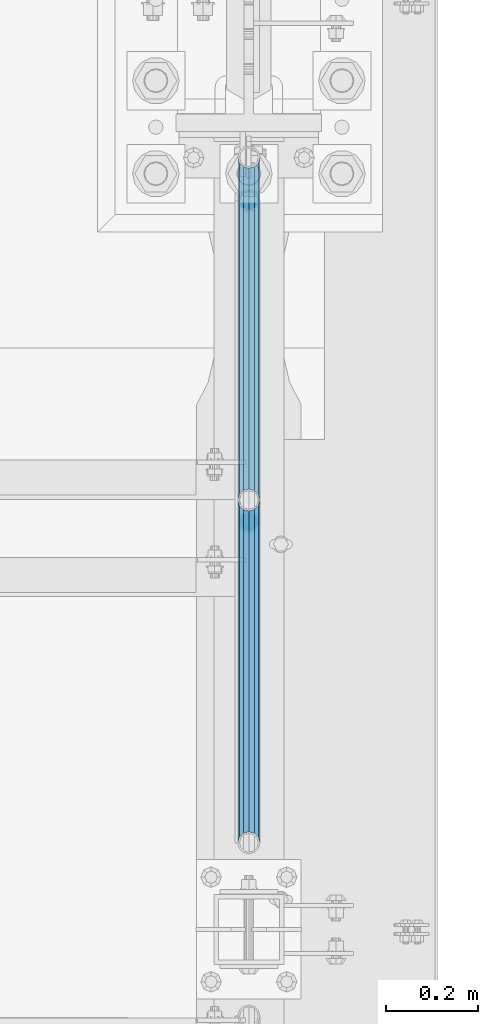
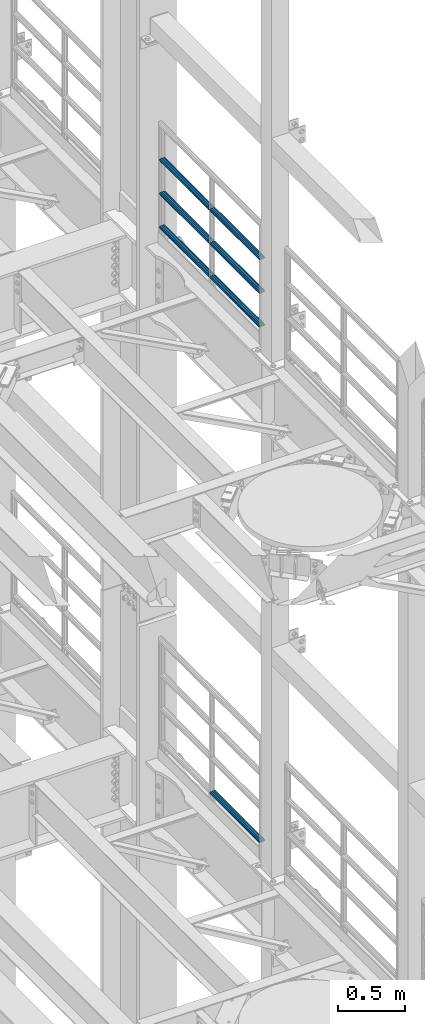
# One storey, part 1334 of 1876: 7 beams, 2 elements without a shape of their own.
"""IFC2X3 building model written with IfcOpenShell, lengths in millimetres."""

from ifc_helpers import new_model, si_unit, frame, origin_with_axes, place, context, subcontext, project, spatial, faceted_brep, material, type_object, element, aggregate, save


model = new_model("IFC2X3")

# Units and contexts
model_context = context("Model", 3, precision=1e-05, world=origin_with_axes())
body_context = subcontext(model_context, "Body", "Model", "MODEL_VIEW")
ifc_project = project(units=[si_unit("LENGTHUNIT", "METRE", prefix="MILLI"), si_unit("AREAUNIT", "SQUARE_METRE"), si_unit("VOLUMEUNIT", "CUBIC_METRE"), si_unit("MASSUNIT", "GRAM", prefix="KILO"), si_unit("TIMEUNIT", "SECOND"), si_unit("PLANEANGLEUNIT", "RADIAN"), si_unit("SOLIDANGLEUNIT", "STERADIAN"), si_unit("THERMODYNAMICTEMPERATUREUNIT", "DEGREE_CELSIUS"), si_unit("LUMINOUSINTENSITYUNIT", "LUMEN")], contexts=[model_context])

# Site, building, storey
site_placement = place(None, origin_with_axes())
site = spatial("IfcSite", under=ifc_project, at=site_placement, CompositionType="ELEMENT")
building_placement = place(site_placement, origin_with_axes())
building = spatial("IfcBuilding", under=site, at=building_placement, Name="Undefined", CompositionType="ELEMENT")
storey_placement = place(building_placement, origin_with_axes())
storey = spatial("IfcBuildingStorey", under=building, at=storey_placement, Name="Undefined", CompositionType="ELEMENT", Elevation=0.0)

# Assembly, beams
assembly_1_placement = place(storey_placement, origin_with_axes())
assembly_1 = element("IfcElementAssembly", 1, at=assembly_1_placement, inside=storey, Name="RAIL", AssemblyPlace="NOTDEFINED", PredefinedType="RIGID_FRAME")
ifc_material = material()
beam_type = type_object("IfcBeamType", Name="PIPE1-1/2SCH40", PredefinedType="NOTDEFINED")
beam_1_placement = place(assembly_1_placement, frame((7620.0, 6526.2125, 18145.125), z_axis=(0.0, 0.0, 1.0), x_axis=(0.0, -1.0, 0.0)))
beam_1 = element("IfcBeam", 2, at=beam_1_placement, type_object=beam_type, material=ifc_material, Name="RAIL", ObjectType="PIPE1-1/2SCH40", context=body_context, shape_type="Brep", body=[
    faceted_brep([(728.085307006683, -12.0649999999996, 20.8971929933177), (728.085307006683, -12.0649999999996, 15.8661214311796), (727.591878568821, -10.2235000000001, 17.7076214311819), (724.852500000002, 0.0, 20.4470000000001), (724.852500000002, 0.0, 24.130000000001), (727.591878568821, 10.2235000000001, 17.7076214311819), (728.085307006683, 12.0649999999996, 15.8661214311796), (728.085307006683, 12.0649999999996, 20.8971929933177), (748.982500000002, 24.1300000000001, 0.0), (736.917500000002, 20.8971929933186, 12.0649999999987), (736.917500000002, 20.8971929933186, -12.0649999999987), (733.727928437864, 17.7076214311801, 10.2235000000001), (736.467307006683, 20.4470000000001, 0.0), (733.727928437864, 17.7076214311801, -10.2235000000001), (728.085307006683, 12.0649999999996, -15.8661214311796), (728.085307006683, 12.0649999999996, -20.8971929933177), (727.591878568821, 10.2235000000001, -17.7076214311819), (724.852500000002, 0.0, -20.4470000000001), (724.852500000002, 0.0, -24.130000000001), (728.085307006683, -12.0649999999996, -15.8661214311796), (728.085307006683, -12.0649999999996, -20.8971929933177), (727.591878568821, -10.2235000000001, -17.7076214311819), (748.982500000002, -24.1300000000001, 0.0), (736.917500000002, -20.8971929933186, -12.0649999999987), (736.917500000002, -20.8971929933186, 12.0649999999987), (733.727928437864, -17.7076214311801, -10.2235000000001), (736.467307006683, -20.4470000000001, 0.0), (733.727928437864, -17.7076214311801, 10.2235000000001), (12.0650000000064, -20.8971929933177, -12.0649999999987), (20.8971929933249, -12.0650000000005, -20.8971929933177), (0.0, 24.1299999999992, 0.0), (12.0650000000064, 20.8971929933177, -12.0649999999987), (12.0650000000064, 20.8971929933177, 12.0649999999987), (20.8971929933249, 12.0650000000005, 20.8971929933177), (24.1300000000064, 0.0, 24.130000000001), (20.8971929933249, 12.0650000000005, -20.8971929933177), (24.1300000000063, 0.0, -24.130000000001), (24.1300000000063, 0.0, -20.4470000000001), (20.8971929933249, -12.0650000000005, -15.8661214311796), (21.3906214311868, -10.2235000000001, -17.7076214311819), (21.3906214311868, 10.2235000000001, -17.7076214311819), (20.8971929933249, 12.0650000000005, -15.8661214311796), (15.2545715621445, 17.7076214311801, -10.2235000000001), (12.5151929933249, 20.4470000000001, 0.0), (15.2545715621445, 17.7076214311801, 10.2235000000001), (20.8971929933249, 12.0650000000005, 15.8661214311796), (21.3906214311868, 10.2235000000001, 17.7076214311819), (24.1300000000064, 0.0, 20.4470000000001), (21.3906214311868, -10.2235000000001, 17.7076214311819), (20.8971929933249, -12.0650000000005, 15.8661214311796), (20.8971929933249, -12.0650000000005, 20.8971929933177), (12.0650000000064, -20.8971929933177, 12.0649999999987), (0.0, -24.1299999999992, 0.0), (15.2545715621445, -17.7076214311801, 10.2235000000001), (12.5151929933249, -20.4470000000001, 0.0), (15.2545715621445, -17.7076214311801, -10.2235000000001)], [[[0, 1, 2, 3, 4]], [[4, 3, 5, 6, 7]], [[8, 9, 10]], [[7, 6, 11, 12, 13, 14, 15, 10, 9]], [[16, 17, 18, 15, 14]], [[19, 20, 18, 17, 21]], [[22, 23, 24]], [[24, 23, 20, 19, 25, 26, 27, 1, 0]], [[28, 29, 20, 23]], [[30, 31, 32]], [[33, 34, 4, 7]], [[32, 33, 7, 9]], [[30, 32, 9, 8]], [[31, 30, 8, 10]], [[35, 31, 10, 15]], [[36, 35, 15, 18]], [[29, 36, 18, 20]], [[37, 36, 29, 38, 39]], [[40, 41, 35, 36, 37]], [[32, 31, 35, 41, 42, 43, 44, 45, 33]], [[33, 45, 46, 47, 34]], [[34, 47, 48, 49, 50]], [[34, 50, 0, 4]], [[50, 51, 24, 0]], [[51, 52, 22, 24]], [[52, 28, 23, 22]], [[51, 28, 52]], [[50, 49, 53, 54, 55, 38, 29, 28, 51]], [[55, 54, 26, 25]], [[21, 39, 38, 55, 25, 19]], [[37, 39, 21, 17]], [[40, 37, 17, 16]], [[42, 41, 40, 16, 14, 13]], [[43, 42, 13, 12]], [[44, 43, 12, 11]], [[5, 46, 45, 44, 11, 6]], [[47, 46, 5, 3]], [[48, 47, 3, 2]], [[53, 49, 48, 2, 1, 27]], [[54, 53, 27, 26]]]),
])
beam_2_placement = place(assembly_1_placement, frame((7619.99999999999, 7275.195, 18145.125), z_axis=(0.0, 0.0, 1.0), x_axis=(0.0, -1.0, 0.0)))
beam_2 = element("IfcBeam", 3, at=beam_2_placement, type_object=beam_type, material=ifc_material, Name="RAIL", ObjectType="PIPE1-1/2SCH40", context=body_context, shape_type="Brep", body=[
    faceted_brep([(728.085307006683, -12.0649999999996, 20.8971929933177), (728.085307006683, -12.0649999999996, 15.8661214311796), (727.591878568821, -10.2235000000001, 17.7076214311819), (724.852500000002, 0.0, 20.4470000000001), (724.852500000002, 0.0, 24.130000000001), (727.591878568821, 10.2235000000001, 17.7076214311819), (728.085307006683, 12.0649999999996, 15.8661214311796), (728.085307006683, 12.0649999999996, 20.8971929933177), (748.982500000002, 24.1300000000001, 0.0), (736.917500000002, 20.8971929933186, 12.0649999999987), (736.917500000002, 20.8971929933186, -12.0649999999987), (733.727928437864, 17.7076214311801, 10.2235000000001), (736.467307006683, 20.4470000000001, 0.0), (733.727928437864, 17.7076214311801, -10.2235000000001), (728.085307006683, 12.0649999999996, -15.8661214311796), (728.085307006683, 12.0649999999996, -20.8971929933177), (727.591878568821, 10.2235000000001, -17.7076214311819), (724.852500000002, 0.0, -20.4470000000001), (724.852500000002, 0.0, -24.130000000001), (728.085307006683, -12.0649999999996, -15.8661214311796), (728.085307006683, -12.0649999999996, -20.8971929933177), (727.591878568821, -10.2235000000001, -17.7076214311819), (748.982500000002, -24.1300000000001, 0.0), (736.917500000002, -20.8971929933186, -12.0649999999987), (736.917500000002, -20.8971929933186, 12.0649999999987), (733.727928437864, -17.7076214311801, -10.2235000000001), (736.467307006683, -20.4470000000001, 0.0), (733.727928437864, -17.7076214311801, 10.2235000000001), (12.0650000000064, -20.8971929933177, -12.0649999999987), (20.8971929933249, -12.0650000000005, -20.8971929933177), (0.0, 24.1299999999992, 0.0), (12.0650000000064, 20.8971929933177, -12.0649999999987), (12.0650000000064, 20.8971929933177, 12.0649999999987), (20.8971929933249, 12.0650000000005, 20.8971929933177), (24.1300000000064, 0.0, 24.130000000001), (20.8971929933249, 12.0650000000005, -20.8971929933177), (24.1300000000063, 0.0, -24.130000000001), (24.1300000000063, 0.0, -20.4470000000001), (20.8971929933249, -12.0650000000005, -15.8661214311796), (21.3906214311868, -10.2235000000001, -17.7076214311819), (21.3906214311868, 10.2235000000001, -17.7076214311819), (20.8971929933249, 12.0650000000005, -15.8661214311796), (15.2545715621445, 17.7076214311801, -10.2235000000001), (12.5151929933249, 20.4470000000001, 0.0), (15.2545715621445, 17.7076214311801, 10.2235000000001), (20.8971929933249, 12.0650000000005, 15.8661214311796), (21.3906214311868, 10.2235000000001, 17.7076214311819), (24.1300000000064, 0.0, 20.4470000000001), (21.3906214311868, -10.2235000000001, 17.7076214311819), (20.8971929933249, -12.0650000000005, 15.8661214311796), (20.8971929933249, -12.0650000000005, 20.8971929933177), (12.0650000000064, -20.8971929933177, 12.0649999999987), (0.0, -24.1299999999992, 0.0), (15.2545715621445, -17.7076214311801, 10.2235000000001), (12.5151929933249, -20.4470000000001, 0.0), (15.2545715621445, -17.7076214311801, -10.2235000000001)], [[[0, 1, 2, 3, 4]], [[4, 3, 5, 6, 7]], [[8, 9, 10]], [[7, 6, 11, 12, 13, 14, 15, 10, 9]], [[16, 17, 18, 15, 14]], [[19, 20, 18, 17, 21]], [[22, 23, 24]], [[24, 23, 20, 19, 25, 26, 27, 1, 0]], [[28, 29, 20, 23]], [[30, 31, 32]], [[33, 34, 4, 7]], [[32, 33, 7, 9]], [[30, 32, 9, 8]], [[31, 30, 8, 10]], [[35, 31, 10, 15]], [[36, 35, 15, 18]], [[29, 36, 18, 20]], [[37, 36, 29, 38, 39]], [[40, 41, 35, 36, 37]], [[32, 31, 35, 41, 42, 43, 44, 45, 33]], [[33, 45, 46, 47, 34]], [[34, 47, 48, 49, 50]], [[34, 50, 0, 4]], [[50, 51, 24, 0]], [[51, 52, 22, 24]], [[52, 28, 23, 22]], [[51, 28, 52]], [[50, 49, 53, 54, 55, 38, 29, 28, 51]], [[55, 54, 26, 25]], [[21, 39, 38, 55, 25, 19]], [[37, 39, 21, 17]], [[40, 37, 17, 16]], [[42, 41, 40, 16, 14, 13]], [[43, 42, 13, 12]], [[44, 43, 12, 11]], [[5, 46, 45, 44, 11, 6]], [[47, 46, 5, 3]], [[48, 47, 3, 2]], [[53, 49, 48, 2, 1, 27]], [[54, 53, 27, 26]]]),
])
beam_3_placement = place(assembly_1_placement, frame((7620.0, 5777.23, 18449.925), z_axis=(0.0, 0.0, -1.0), x_axis=(0.0, 1.0, 0.0)))
beam_3 = element("IfcBeam", 4, at=beam_3_placement, type_object=beam_type, material=ifc_material, Name="RAIL", ObjectType="PIPE1-1/2SCH40", context=body_context, shape_type="Brep", body=[
    faceted_brep([(0.0, 24.1299999999992, 0.0), (12.0650000000064, 20.8971929933177, -12.0649999999987), (12.0650000000064, 20.8971929933177, 12.0649999999987), (12.0650000000064, -20.8971929933177, 12.0649999999987), (12.0650000000064, -20.8971929933177, -12.0649999999987), (0.0, -24.1299999999992, 0.0), (20.8971929933249, -12.0650000000005, 20.8971929933177), (20.8971929933249, -12.0650000000005, 15.8661214311796), (15.2545715621445, -17.7076214311801, 10.2235000000001), (12.5151929933249, -20.4470000000001, 0.0), (15.2545715621445, -17.7076214311801, -10.2235000000001), (20.8971929933249, -12.0650000000005, -15.8661214311796), (20.8971929933249, -12.0650000000005, -20.8971929933177), (24.1300000000063, 0.0, -20.4470000000001), (24.1300000000063, 0.0, -24.130000000001), (21.3906214311868, -10.2235000000001, -17.7076214311819), (21.3906214311868, 10.2235000000001, -17.7076214311819), (20.8971929933249, 12.0650000000005, -15.8661214311796), (20.8971929933249, 12.0650000000005, -20.8971929933177), (15.2545715621445, 17.7076214311801, -10.2235000000001), (12.5151929933249, 20.4470000000001, 0.0), (15.2545715621445, 17.7076214311801, 10.2235000000001), (20.8971929933249, 12.0650000000005, 15.8661214311796), (20.8971929933249, 12.0650000000005, 20.8971929933177), (21.3906214311868, 10.2235000000001, 17.7076214311819), (24.1300000000064, 0.0, 20.4470000000001), (24.1300000000064, 0.0, 24.130000000001), (21.3906214311868, -10.2235000000001, 17.7076214311819), (748.982500000002, 24.1300000000001, 0.0), (736.917500000002, 20.8971929933186, -12.0649999999987), (728.085307006683, 12.0649999999996, -20.8971929933177), (748.982500000002, -24.1300000000001, 0.0), (736.917500000002, -20.8971929933186, -12.0649999999987), (736.917500000002, -20.8971929933186, 12.0649999999987), (728.085307006683, -12.0649999999996, 20.8971929933177), (728.085307006683, -12.0649999999996, -20.8971929933177), (724.852500000002, 0.0, -24.130000000001), (727.591878568821, 10.2235000000001, -17.7076214311819), (724.852500000002, 0.0, -20.4470000000001), (728.085307006683, 12.0649999999996, -15.8661214311796), (728.085307006683, -12.0649999999996, -15.8661214311796), (727.591878568821, -10.2235000000001, -17.7076214311819), (733.727928437864, -17.7076214311801, -10.2235000000001), (736.467307006683, -20.4470000000001, 0.0), (733.727928437864, -17.7076214311801, 10.2235000000001), (728.085307006683, -12.0649999999996, 15.8661214311796), (727.591878568821, -10.2235000000001, 17.7076214311819), (724.852500000002, 0.0, 20.4470000000001), (724.852500000002, 0.0, 24.130000000001), (728.085307006683, 12.0649999999996, 20.8971929933177), (736.917500000002, 20.8971929933186, 12.0649999999987), (728.085307006683, 12.0649999999996, 15.8661214311796), (733.727928437864, 17.7076214311801, 10.2235000000001), (736.467307006683, 20.4470000000001, 0.0), (733.727928437864, 17.7076214311801, -10.2235000000001), (727.591878568821, 10.2235000000001, 17.7076214311819)], [[[0, 1, 2]], [[3, 4, 5]], [[6, 7, 8, 9, 10, 11, 12, 4, 3]], [[13, 14, 12, 11, 15]], [[16, 17, 18, 14, 13]], [[2, 1, 18, 17, 19, 20, 21, 22, 23]], [[23, 22, 24, 25, 26]], [[26, 25, 27, 7, 6]], [[1, 0, 28, 29]], [[18, 1, 29, 30]], [[31, 32, 33]], [[6, 3, 33, 34]], [[3, 5, 31, 33]], [[5, 4, 32, 31]], [[4, 12, 35, 32]], [[12, 14, 36, 35]], [[14, 18, 30, 36]], [[37, 38, 36, 30, 39]], [[40, 35, 36, 38, 41]], [[33, 32, 35, 40, 42, 43, 44, 45, 34]], [[34, 45, 46, 47, 48]], [[26, 6, 34, 48]], [[2, 23, 49, 50]], [[23, 26, 48, 49]], [[0, 2, 50, 28]], [[28, 50, 29]], [[49, 51, 52, 53, 54, 39, 30, 29, 50]], [[48, 47, 55, 51, 49]], [[25, 24, 55, 47]], [[55, 24, 22, 21, 52, 51]], [[21, 20, 53, 52]], [[20, 19, 54, 53]], [[19, 17, 16, 37, 39, 54]], [[16, 13, 38, 37]], [[13, 15, 41, 38]], [[41, 15, 11, 10, 42, 40]], [[10, 9, 43, 42]], [[9, 8, 44, 43]], [[8, 7, 27, 46, 45, 44]], [[27, 25, 47, 46]]]),
])
beam_4_placement = place(assembly_1_placement, frame((7620.0, 6526.2125, 18449.925), z_axis=(0.0, 0.0, -1.0), x_axis=(0.0, 1.0, 0.0)))
beam_4 = element("IfcBeam", 5, at=beam_4_placement, type_object=beam_type, material=ifc_material, Name="RAIL", ObjectType="PIPE1-1/2SCH40", context=body_context, shape_type="Brep", body=[
    faceted_brep([(0.0, 24.1299999999992, 0.0), (12.0650000000064, 20.8971929933177, -12.0649999999987), (12.0650000000064, 20.8971929933177, 12.0649999999987), (12.0650000000064, -20.8971929933177, 12.0649999999987), (12.0650000000064, -20.8971929933177, -12.0649999999987), (0.0, -24.1299999999992, 0.0), (20.8971929933249, -12.0650000000005, 20.8971929933177), (20.8971929933249, -12.0650000000005, 15.8661214311796), (15.2545715621445, -17.7076214311801, 10.2235000000001), (12.5151929933249, -20.4470000000001, 0.0), (15.2545715621445, -17.7076214311801, -10.2235000000001), (20.8971929933249, -12.0650000000005, -15.8661214311796), (20.8971929933249, -12.0650000000005, -20.8971929933177), (24.1300000000063, 0.0, -20.4470000000001), (24.1300000000063, 0.0, -24.130000000001), (21.3906214311868, -10.2235000000001, -17.7076214311819), (21.3906214311868, 10.2235000000001, -17.7076214311819), (20.8971929933249, 12.0650000000005, -15.8661214311796), (20.8971929933249, 12.0650000000005, -20.8971929933177), (15.2545715621445, 17.7076214311801, -10.2235000000001), (12.5151929933249, 20.4470000000001, 0.0), (15.2545715621445, 17.7076214311801, 10.2235000000001), (20.8971929933249, 12.0650000000005, 15.8661214311796), (20.8971929933249, 12.0650000000005, 20.8971929933177), (21.3906214311868, 10.2235000000001, 17.7076214311819), (24.1300000000064, 0.0, 20.4470000000001), (24.1300000000064, 0.0, 24.130000000001), (21.3906214311868, -10.2235000000001, 17.7076214311819), (748.982500000002, 24.1300000000001, 0.0), (736.917500000002, 20.8971929933186, -12.0649999999987), (728.085307006683, 12.0649999999996, -20.8971929933177), (748.982500000002, -24.1300000000001, 0.0), (736.917500000002, -20.8971929933186, -12.0649999999987), (736.917500000002, -20.8971929933186, 12.0649999999987), (728.085307006683, -12.0649999999996, 20.8971929933177), (728.085307006683, -12.0649999999996, -20.8971929933177), (724.852500000002, 0.0, -24.130000000001), (727.591878568821, 10.2235000000001, -17.7076214311819), (724.852500000002, 0.0, -20.4470000000001), (728.085307006683, 12.0649999999996, -15.8661214311796), (728.085307006683, -12.0649999999996, -15.8661214311796), (727.591878568821, -10.2235000000001, -17.7076214311819), (733.727928437864, -17.7076214311801, -10.2235000000001), (736.467307006683, -20.4470000000001, 0.0), (733.727928437864, -17.7076214311801, 10.2235000000001), (728.085307006683, -12.0649999999996, 15.8661214311796), (727.591878568821, -10.2235000000001, 17.7076214311819), (724.852500000002, 0.0, 20.4470000000001), (724.852500000002, 0.0, 24.130000000001), (728.085307006683, 12.0649999999996, 20.8971929933177), (736.917500000002, 20.8971929933186, 12.0649999999987), (728.085307006683, 12.0649999999996, 15.8661214311796), (733.727928437864, 17.7076214311801, 10.2235000000001), (736.467307006683, 20.4470000000001, 0.0), (733.727928437864, 17.7076214311801, -10.2235000000001), (727.591878568821, 10.2235000000001, 17.7076214311819)], [[[0, 1, 2]], [[3, 4, 5]], [[6, 7, 8, 9, 10, 11, 12, 4, 3]], [[13, 14, 12, 11, 15]], [[16, 17, 18, 14, 13]], [[2, 1, 18, 17, 19, 20, 21, 22, 23]], [[23, 22, 24, 25, 26]], [[26, 25, 27, 7, 6]], [[1, 0, 28, 29]], [[18, 1, 29, 30]], [[31, 32, 33]], [[6, 3, 33, 34]], [[3, 5, 31, 33]], [[5, 4, 32, 31]], [[4, 12, 35, 32]], [[12, 14, 36, 35]], [[14, 18, 30, 36]], [[37, 38, 36, 30, 39]], [[40, 35, 36, 38, 41]], [[33, 32, 35, 40, 42, 43, 44, 45, 34]], [[34, 45, 46, 47, 48]], [[26, 6, 34, 48]], [[2, 23, 49, 50]], [[23, 26, 48, 49]], [[0, 2, 50, 28]], [[28, 50, 29]], [[49, 51, 52, 53, 54, 39, 30, 29, 50]], [[48, 47, 55, 51, 49]], [[25, 24, 55, 47]], [[55, 24, 22, 21, 52, 51]], [[21, 20, 53, 52]], [[20, 19, 54, 53]], [[19, 17, 16, 37, 39, 54]], [[16, 13, 38, 37]], [[13, 15, 41, 38]], [[41, 15, 11, 10, 42, 40]], [[10, 9, 43, 42]], [[9, 8, 44, 43]], [[8, 7, 27, 46, 45, 44]], [[27, 25, 47, 46]]]),
])
beam_5_placement = place(assembly_1_placement, frame((7620.0, 5777.23, 18754.725), z_axis=(0.0, 0.0, -1.0), x_axis=(0.0, 1.0, 0.0)))
beam_5 = element("IfcBeam", 6, at=beam_5_placement, type_object=beam_type, material=ifc_material, Name="RAIL", ObjectType="PIPE1-1/2SCH40", context=body_context, shape_type="Brep", body=[
    faceted_brep([(0.0, 24.1299999999992, 0.0), (12.0650000000064, 20.8971929933177, -12.0649999999987), (12.0650000000064, 20.8971929933177, 12.0649999999987), (12.0650000000064, -20.8971929933177, 12.0649999999987), (12.0650000000064, -20.8971929933177, -12.0649999999987), (0.0, -24.1299999999992, 0.0), (20.8971929933249, -12.0650000000005, 20.8971929933177), (20.8971929933249, -12.0650000000005, 15.8661214311796), (15.2545715621445, -17.7076214311801, 10.2235000000001), (12.5151929933249, -20.4470000000001, 0.0), (15.2545715621445, -17.7076214311801, -10.2235000000001), (20.8971929933249, -12.0650000000005, -15.8661214311796), (20.8971929933249, -12.0650000000005, -20.8971929933177), (24.1300000000063, 0.0, -20.4470000000001), (24.1300000000063, 0.0, -24.130000000001), (21.3906214311868, -10.2235000000001, -17.7076214311819), (21.3906214311868, 10.2235000000001, -17.7076214311819), (20.8971929933249, 12.0650000000005, -15.8661214311796), (20.8971929933249, 12.0650000000005, -20.8971929933177), (15.2545715621445, 17.7076214311801, -10.2235000000001), (12.5151929933249, 20.4470000000001, 0.0), (15.2545715621445, 17.7076214311801, 10.2235000000001), (20.8971929933249, 12.0650000000005, 15.8661214311796), (20.8971929933249, 12.0650000000005, 20.8971929933177), (21.3906214311868, 10.2235000000001, 17.7076214311819), (24.1300000000064, 0.0, 20.4470000000001), (24.1300000000064, 0.0, 24.130000000001), (21.3906214311868, -10.2235000000001, 17.7076214311819), (748.982500000002, 24.1300000000001, 0.0), (736.917500000002, 20.8971929933186, -12.0649999999987), (728.085307006683, 12.0649999999996, -20.8971929933177), (748.982500000002, -24.1300000000001, 0.0), (736.917500000002, -20.8971929933186, -12.0649999999987), (736.917500000002, -20.8971929933186, 12.0649999999987), (728.085307006683, -12.0649999999996, 20.8971929933177), (728.085307006683, -12.0649999999996, -20.8971929933177), (724.852500000002, 0.0, -24.130000000001), (727.591878568821, 10.2235000000001, -17.7076214311819), (724.852500000002, 0.0, -20.4470000000001), (728.085307006683, 12.0649999999996, -15.8661214311796), (728.085307006683, -12.0649999999996, -15.8661214311796), (727.591878568821, -10.2235000000001, -17.7076214311819), (733.727928437864, -17.7076214311801, -10.2235000000001), (736.467307006683, -20.4470000000001, 0.0), (733.727928437864, -17.7076214311801, 10.2235000000001), (728.085307006683, -12.0649999999996, 15.8661214311796), (727.591878568821, -10.2235000000001, 17.7076214311819), (724.852500000002, 0.0, 20.4470000000001), (724.852500000002, 0.0, 24.130000000001), (728.085307006683, 12.0649999999996, 20.8971929933177), (736.917500000002, 20.8971929933186, 12.0649999999987), (728.085307006683, 12.0649999999996, 15.8661214311796), (733.727928437864, 17.7076214311801, 10.2235000000001), (736.467307006683, 20.4470000000001, 0.0), (733.727928437864, 17.7076214311801, -10.2235000000001), (727.591878568821, 10.2235000000001, 17.7076214311819)], [[[0, 1, 2]], [[3, 4, 5]], [[6, 7, 8, 9, 10, 11, 12, 4, 3]], [[13, 14, 12, 11, 15]], [[16, 17, 18, 14, 13]], [[2, 1, 18, 17, 19, 20, 21, 22, 23]], [[23, 22, 24, 25, 26]], [[26, 25, 27, 7, 6]], [[1, 0, 28, 29]], [[18, 1, 29, 30]], [[31, 32, 33]], [[6, 3, 33, 34]], [[3, 5, 31, 33]], [[5, 4, 32, 31]], [[4, 12, 35, 32]], [[12, 14, 36, 35]], [[14, 18, 30, 36]], [[37, 38, 36, 30, 39]], [[40, 35, 36, 38, 41]], [[33, 32, 35, 40, 42, 43, 44, 45, 34]], [[34, 45, 46, 47, 48]], [[26, 6, 34, 48]], [[2, 23, 49, 50]], [[23, 26, 48, 49]], [[0, 2, 50, 28]], [[28, 50, 29]], [[49, 51, 52, 53, 54, 39, 30, 29, 50]], [[48, 47, 55, 51, 49]], [[25, 24, 55, 47]], [[55, 24, 22, 21, 52, 51]], [[21, 20, 53, 52]], [[20, 19, 54, 53]], [[19, 17, 16, 37, 39, 54]], [[16, 13, 38, 37]], [[13, 15, 41, 38]], [[41, 15, 11, 10, 42, 40]], [[10, 9, 43, 42]], [[9, 8, 44, 43]], [[8, 7, 27, 46, 45, 44]], [[27, 25, 47, 46]]]),
])
beam_6_placement = place(assembly_1_placement, frame((7620.0, 6526.2125, 18754.725), z_axis=(0.0, 0.0, -1.0), x_axis=(0.0, 1.0, 0.0)))
beam_6 = element("IfcBeam", 7, at=beam_6_placement, type_object=beam_type, material=ifc_material, Name="RAIL", ObjectType="PIPE1-1/2SCH40", context=body_context, shape_type="Brep", body=[
    faceted_brep([(0.0, 24.1299999999992, 0.0), (12.0650000000064, 20.8971929933177, -12.0649999999987), (12.0650000000064, 20.8971929933177, 12.0649999999987), (12.0650000000064, -20.8971929933177, 12.0649999999987), (12.0650000000064, -20.8971929933177, -12.0649999999987), (0.0, -24.1299999999992, 0.0), (20.8971929933249, -12.0650000000005, 20.8971929933177), (20.8971929933249, -12.0650000000005, 15.8661214311796), (15.2545715621445, -17.7076214311801, 10.2235000000001), (12.5151929933249, -20.4470000000001, 0.0), (15.2545715621445, -17.7076214311801, -10.2235000000001), (20.8971929933249, -12.0650000000005, -15.8661214311796), (20.8971929933249, -12.0650000000005, -20.8971929933177), (24.1300000000063, 0.0, -20.4470000000001), (24.1300000000063, 0.0, -24.130000000001), (21.3906214311868, -10.2235000000001, -17.7076214311819), (21.3906214311868, 10.2235000000001, -17.7076214311819), (20.8971929933249, 12.0650000000005, -15.8661214311796), (20.8971929933249, 12.0650000000005, -20.8971929933177), (15.2545715621445, 17.7076214311801, -10.2235000000001), (12.5151929933249, 20.4470000000001, 0.0), (15.2545715621445, 17.7076214311801, 10.2235000000001), (20.8971929933249, 12.0650000000005, 15.8661214311796), (20.8971929933249, 12.0650000000005, 20.8971929933177), (21.3906214311868, 10.2235000000001, 17.7076214311819), (24.1300000000064, 0.0, 20.4470000000001), (24.1300000000064, 0.0, 24.130000000001), (21.3906214311868, -10.2235000000001, 17.7076214311819), (748.982500000002, 24.1300000000001, 0.0), (736.917500000002, 20.8971929933186, -12.0649999999987), (728.085307006683, 12.0649999999996, -20.8971929933177), (748.982500000002, -24.1300000000001, 0.0), (736.917500000002, -20.8971929933186, -12.0649999999987), (736.917500000002, -20.8971929933186, 12.0649999999987), (728.085307006683, -12.0649999999996, 20.8971929933177), (728.085307006683, -12.0649999999996, -20.8971929933177), (724.852500000002, 0.0, -24.130000000001), (727.591878568821, 10.2235000000001, -17.7076214311819), (724.852500000002, 0.0, -20.4470000000001), (728.085307006683, 12.0649999999996, -15.8661214311796), (728.085307006683, -12.0649999999996, -15.8661214311796), (727.591878568821, -10.2235000000001, -17.7076214311819), (733.727928437864, -17.7076214311801, -10.2235000000001), (736.467307006683, -20.4470000000001, 0.0), (733.727928437864, -17.7076214311801, 10.2235000000001), (728.085307006683, -12.0649999999996, 15.8661214311796), (727.591878568821, -10.2235000000001, 17.7076214311819), (724.852500000002, 0.0, 20.4470000000001), (724.852500000002, 0.0, 24.130000000001), (728.085307006683, 12.0649999999996, 20.8971929933177), (736.917500000002, 20.8971929933186, 12.0649999999987), (728.085307006683, 12.0649999999996, 15.8661214311796), (733.727928437864, 17.7076214311801, 10.2235000000001), (736.467307006683, 20.4470000000001, 0.0), (733.727928437864, 17.7076214311801, -10.2235000000001), (727.591878568821, 10.2235000000001, 17.7076214311819)], [[[0, 1, 2]], [[3, 4, 5]], [[6, 7, 8, 9, 10, 11, 12, 4, 3]], [[13, 14, 12, 11, 15]], [[16, 17, 18, 14, 13]], [[2, 1, 18, 17, 19, 20, 21, 22, 23]], [[23, 22, 24, 25, 26]], [[26, 25, 27, 7, 6]], [[1, 0, 28, 29]], [[18, 1, 29, 30]], [[31, 32, 33]], [[6, 3, 33, 34]], [[3, 5, 31, 33]], [[5, 4, 32, 31]], [[4, 12, 35, 32]], [[12, 14, 36, 35]], [[14, 18, 30, 36]], [[37, 38, 36, 30, 39]], [[40, 35, 36, 38, 41]], [[33, 32, 35, 40, 42, 43, 44, 45, 34]], [[34, 45, 46, 47, 48]], [[26, 6, 34, 48]], [[2, 23, 49, 50]], [[23, 26, 48, 49]], [[0, 2, 50, 28]], [[28, 50, 29]], [[49, 51, 52, 53, 54, 39, 30, 29, 50]], [[48, 47, 55, 51, 49]], [[25, 24, 55, 47]], [[55, 24, 22, 21, 52, 51]], [[21, 20, 53, 52]], [[20, 19, 54, 53]], [[19, 17, 16, 37, 39, 54]], [[16, 13, 38, 37]], [[13, 15, 41, 38]], [[41, 15, 11, 10, 42, 40]], [[10, 9, 43, 42]], [[9, 8, 44, 43]], [[8, 7, 27, 46, 45, 44]], [[27, 25, 47, 46]]]),
])
aggregate(assembly_1, [beam_1, beam_2, beam_3, beam_4, beam_5, beam_6])

# Assembly, beam
assembly_2_placement = place(storey_placement, origin_with_axes())
assembly_2 = element("IfcElementAssembly", 8, at=assembly_2_placement, inside=storey, Name="RAIL", AssemblyPlace="NOTDEFINED", PredefinedType="RIGID_FRAME")
beam_7_placement = place(assembly_2_placement, frame((7620.0, 6526.2125, 13471.525), z_axis=(0.0, 0.0, 1.0), x_axis=(0.0, -1.0, 0.0)))
beam_7 = element("IfcBeam", 9, at=beam_7_placement, type_object=beam_type, material=ifc_material, Name="RAIL", ObjectType="PIPE1-1/2SCH40", context=body_context, shape_type="Brep", body=[
    faceted_brep([(728.085307006683, -12.0649999999996, 20.8971929933177), (728.085307006683, -12.0649999999996, 15.8661214311796), (727.591878568821, -10.2235000000001, 17.7076214311819), (724.852500000002, 0.0, 20.4470000000001), (724.852500000002, 0.0, 24.130000000001), (727.591878568821, 10.2235000000001, 17.7076214311819), (728.085307006683, 12.0649999999996, 15.8661214311796), (728.085307006683, 12.0649999999996, 20.8971929933177), (748.982500000002, 24.1300000000001, 0.0), (736.917500000002, 20.8971929933186, 12.0649999999987), (736.917500000002, 20.8971929933186, -12.0649999999987), (733.727928437864, 17.7076214311801, 10.2235000000001), (736.467307006683, 20.4470000000001, 0.0), (733.727928437864, 17.7076214311801, -10.2235000000001), (728.085307006683, 12.0649999999996, -15.8661214311796), (728.085307006683, 12.0649999999996, -20.8971929933177), (727.591878568821, 10.2235000000001, -17.7076214311819), (724.852500000002, 0.0, -20.4470000000001), (724.852500000002, 0.0, -24.130000000001), (728.085307006683, -12.0649999999996, -15.8661214311796), (728.085307006683, -12.0649999999996, -20.8971929933177), (727.591878568821, -10.2235000000001, -17.7076214311819), (748.982500000002, -24.1300000000001, 0.0), (736.917500000002, -20.8971929933186, -12.0649999999987), (736.917500000002, -20.8971929933186, 12.0649999999987), (733.727928437864, -17.7076214311801, -10.2235000000001), (736.467307006683, -20.4470000000001, 0.0), (733.727928437864, -17.7076214311801, 10.2235000000001), (12.0650000000064, -20.8971929933177, -12.0649999999987), (20.8971929933249, -12.0650000000005, -20.8971929933177), (0.0, 24.1299999999992, 0.0), (12.0650000000064, 20.8971929933177, -12.0649999999987), (12.0650000000064, 20.8971929933177, 12.0649999999987), (20.8971929933249, 12.0650000000005, 20.8971929933177), (24.1300000000064, 0.0, 24.130000000001), (20.8971929933249, 12.0650000000005, -20.8971929933177), (24.1300000000063, 0.0, -24.130000000001), (24.1300000000063, 0.0, -20.4470000000001), (20.8971929933249, -12.0650000000005, -15.8661214311796), (21.3906214311868, -10.2235000000001, -17.7076214311819), (21.3906214311868, 10.2235000000001, -17.7076214311819), (20.8971929933249, 12.0650000000005, -15.8661214311796), (15.2545715621445, 17.7076214311801, -10.2235000000001), (12.5151929933249, 20.4470000000001, 0.0), (15.2545715621445, 17.7076214311801, 10.2235000000001), (20.8971929933249, 12.0650000000005, 15.8661214311796), (21.3906214311868, 10.2235000000001, 17.7076214311819), (24.1300000000064, 0.0, 20.4470000000001), (21.3906214311868, -10.2235000000001, 17.7076214311819), (20.8971929933249, -12.0650000000005, 15.8661214311796), (20.8971929933249, -12.0650000000005, 20.8971929933177), (12.0650000000064, -20.8971929933177, 12.0649999999987), (0.0, -24.1299999999992, 0.0), (15.2545715621445, -17.7076214311801, 10.2235000000001), (12.5151929933249, -20.4470000000001, 0.0), (15.2545715621445, -17.7076214311801, -10.2235000000001)], [[[0, 1, 2, 3, 4]], [[4, 3, 5, 6, 7]], [[8, 9, 10]], [[7, 6, 11, 12, 13, 14, 15, 10, 9]], [[16, 17, 18, 15, 14]], [[19, 20, 18, 17, 21]], [[22, 23, 24]], [[24, 23, 20, 19, 25, 26, 27, 1, 0]], [[28, 29, 20, 23]], [[30, 31, 32]], [[33, 34, 4, 7]], [[32, 33, 7, 9]], [[30, 32, 9, 8]], [[31, 30, 8, 10]], [[35, 31, 10, 15]], [[36, 35, 15, 18]], [[29, 36, 18, 20]], [[37, 36, 29, 38, 39]], [[40, 41, 35, 36, 37]], [[32, 31, 35, 41, 42, 43, 44, 45, 33]], [[33, 45, 46, 47, 34]], [[34, 47, 48, 49, 50]], [[34, 50, 0, 4]], [[50, 51, 24, 0]], [[51, 52, 22, 24]], [[52, 28, 23, 22]], [[51, 28, 52]], [[50, 49, 53, 54, 55, 38, 29, 28, 51]], [[55, 54, 26, 25]], [[21, 39, 38, 55, 25, 19]], [[37, 39, 21, 17]], [[40, 37, 17, 16]], [[42, 41, 40, 16, 14, 13]], [[43, 42, 13, 12]], [[44, 43, 12, 11]], [[5, 46, 45, 44, 11, 6]], [[47, 46, 5, 3]], [[48, 47, 3, 2]], [[53, 49, 48, 2, 1, 27]], [[54, 53, 27, 26]]]),
])
aggregate(assembly_2, [beam_7])

save(model, "model.ifc")
